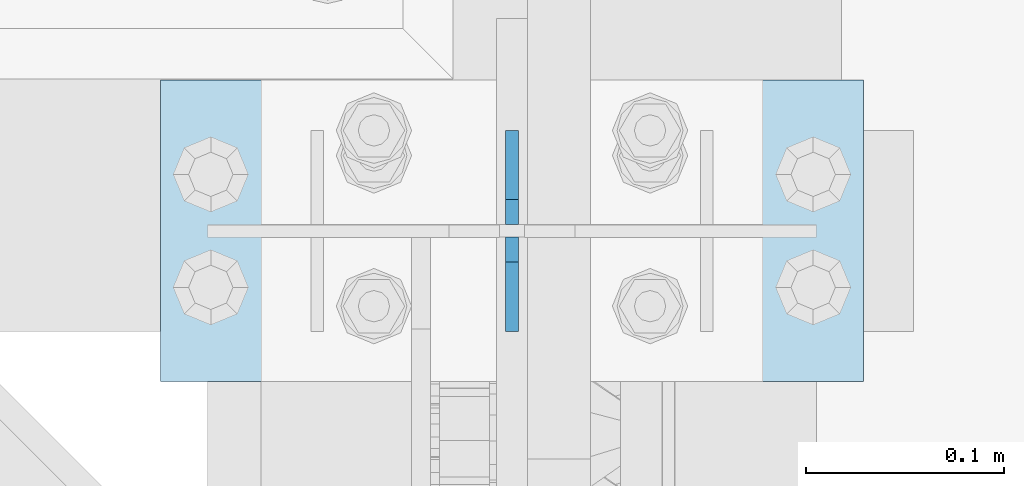
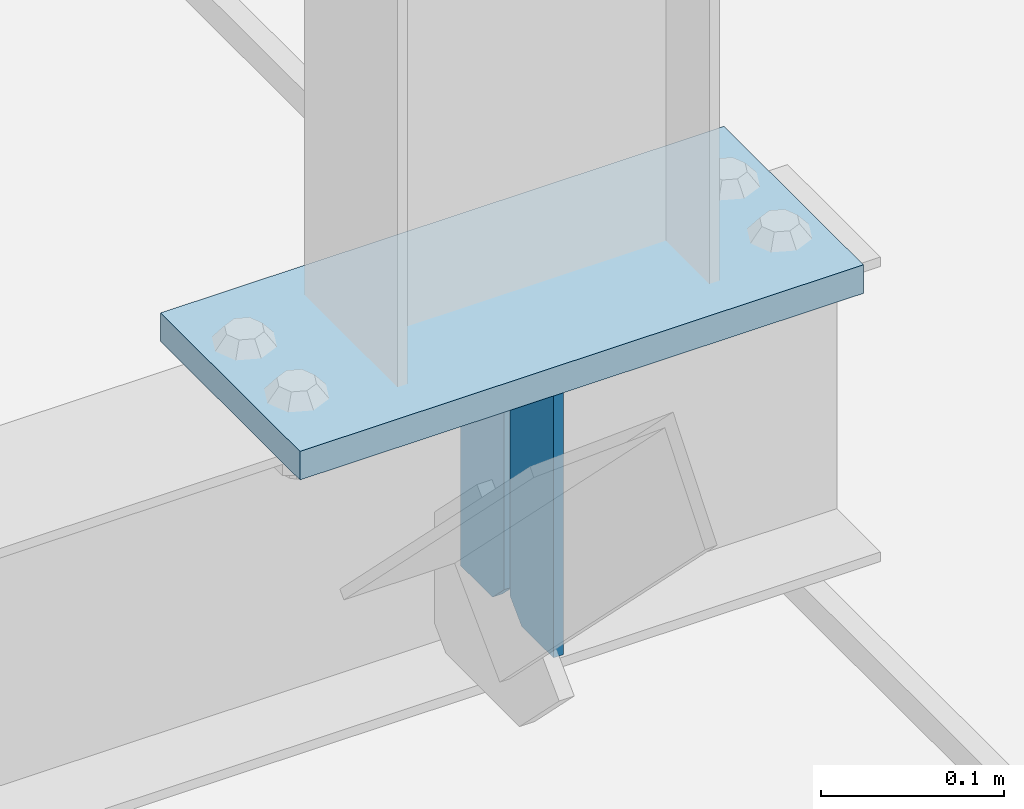
# One storey, part 3036 of 3843: 3 plates, 2 elements without a shape of their own.
"""IFC2X3 building model written with IfcOpenShell, lengths in millimetres."""

from ifc_helpers import new_model, si_unit, frame, origin_with_axes, place, context, subcontext, project, spatial, faceted_brep, material, type_object, element, aggregate, save


model = new_model("IFC2X3")

# Units and contexts
model_context = context("Model", 3, precision=1e-05, world=origin_with_axes())
body_context = subcontext(model_context, "Body", "Model", "MODEL_VIEW")
ifc_project = project(units=[si_unit("LENGTHUNIT", "METRE", prefix="MILLI"), si_unit("AREAUNIT", "SQUARE_METRE"), si_unit("VOLUMEUNIT", "CUBIC_METRE"), si_unit("MASSUNIT", "GRAM", prefix="KILO"), si_unit("TIMEUNIT", "SECOND"), si_unit("PLANEANGLEUNIT", "RADIAN"), si_unit("SOLIDANGLEUNIT", "STERADIAN"), si_unit("THERMODYNAMICTEMPERATUREUNIT", "DEGREE_CELSIUS"), si_unit("LUMINOUSINTENSITYUNIT", "LUMEN")], contexts=[model_context])

# Site, building, storey
site_placement = place(None, origin_with_axes())
site = spatial("IfcSite", under=ifc_project, at=site_placement, CompositionType="ELEMENT")
building_placement = place(site_placement, origin_with_axes())
building = spatial("IfcBuilding", under=site, at=building_placement, Name="Undefined", CompositionType="ELEMENT")
storey_placement = place(building_placement, origin_with_axes())
storey = spatial("IfcBuildingStorey", under=building, at=storey_placement, Name="Undefined", CompositionType="ELEMENT", Elevation=0.0)

# Assembly, plates
assembly_1_placement = place(storey_placement, origin_with_axes())
assembly_1 = element("IfcElementAssembly", 1, at=assembly_1_placement, inside=storey, Name="BEAM", AssemblyPlace="NOTDEFINED", PredefinedType="RIGID_FRAME")
ifc_material = material(Name="STEEL/A572-50")
plate_type_1 = type_object("IfcPlateType", PredefinedType="NOTDEFINED")
plate_1_placement = place(assembly_1_placement, frame((42062.4, 26936.7, 41495.6625), z_axis=(0.0, 0.0, -1.0), x_axis=(0.0, 1.0, 0.0)))
plate_1 = element("IfcPlate", 2, at=plate_1_placement, type_object=plate_type_1, material=ifc_material, Name="PLATE", context=body_context, shape_type="Brep", body=[
    faceted_brep([(0.0, -3.17499999999927, 0.0), (0.0, -3.17500000000291, 187.324999999997), (0.0, 3.17500000000291, 187.324999999997), (0.0, 3.17499999999927, 0.0), (34.9250001907349, -3.17500000000291, 187.324999999997), (34.9250001907349, 3.17500000000291, 187.324999999997), (47.625, -3.17500000000291, 174.625000190732), (47.625, 3.17500000000291, 174.625000190732), (47.625, -3.17499999999927, 12.6999998092651), (47.625, 3.17499999999927, 12.6999998092651), (34.9250001907349, -3.17499999999927, 0.0), (34.9250001907349, 3.17499999999927, 0.0)], [[[0, 1, 2, 3]], [[1, 4, 5, 2]], [[4, 6, 7, 5]], [[6, 8, 9, 7]], [[8, 10, 11, 9]], [[10, 0, 3, 11]], [[5, 7, 9, 11, 3, 2]], [[10, 8, 6, 4, 1, 0]]]),
])
plate_2_placement = place(assembly_1_placement, frame((42062.4, 27038.3, 41495.6625), z_axis=(0.0, 0.0, -1.0), x_axis=(0.0, -1.0, 0.0)))
plate_2 = element("IfcPlate", 3, at=plate_2_placement, type_object=plate_type_1, material=ifc_material, Name="PLATE", context=body_context, shape_type="Brep", body=[
    faceted_brep([(0.0, -3.17499999999927, 0.0), (0.0, -3.17500000000291, 187.324999999997), (0.0, 3.17500000000291, 187.324999999997), (0.0, 3.17499999999927, 0.0), (34.9250001907349, -3.17500000000291, 187.324999999997), (34.9250001907349, 3.17500000000291, 187.324999999997), (47.625, -3.17500000000291, 174.625000190732), (47.625, 3.17500000000291, 174.625000190732), (47.625, -3.17499999999927, 12.6999998092651), (47.625, 3.17499999999927, 12.6999998092651), (34.9250001907349, -3.17499999999927, 0.0), (34.9250001907349, 3.17499999999927, 0.0)], [[[0, 1, 2, 3]], [[1, 4, 5, 2]], [[4, 6, 7, 5]], [[6, 8, 9, 7]], [[8, 10, 11, 9]], [[10, 0, 3, 11]], [[5, 7, 9, 11, 3, 2]], [[10, 8, 6, 4, 1, 0]]]),
])
aggregate(assembly_1, [plate_1, plate_2])

# Assembly, plate
assembly_2_placement = place(storey_placement, origin_with_axes())
assembly_2 = element("IfcElementAssembly", 4, at=assembly_2_placement, inside=storey, Name="POST", AssemblyPlace="NOTDEFINED", PredefinedType="RIGID_FRAME")
plate_type_2 = type_object("IfcPlateType", PredefinedType="NOTDEFINED")
plate_3_placement = place(assembly_2_placement, frame((42240.2, 26911.3, 41513.125), z_axis=(-1.0, 0.0, 0.0), x_axis=(0.0, 1.0, 0.0)))
plate_3 = element("IfcPlate", 5, at=plate_3_placement, type_object=plate_type_2, material=ifc_material, Name="PLATE", context=body_context, shape_type="Brep", body=[
    faceted_brep([(0.0, -9.52500000000146, 0.0), (0.0, -9.52500000000146, 355.599999999999), (0.0, 9.52500000000146, 355.599999999999), (0.0, 9.52500000000146, 0.0), (152.399999999994, -9.52500000000146, 355.599999999999), (152.399999999994, 9.52500000000146, 355.599999999999), (152.400000000001, -9.52500000000146, 0.0), (152.400000000001, 9.52500000000146, 0.0)], [[[0, 1, 2, 3]], [[1, 4, 5, 2]], [[4, 6, 7, 5]], [[6, 0, 3, 7]], [[5, 7, 3, 2]], [[6, 4, 1, 0]]]),
])
aggregate(assembly_2, [plate_3])

save(model, "model.ifc")
